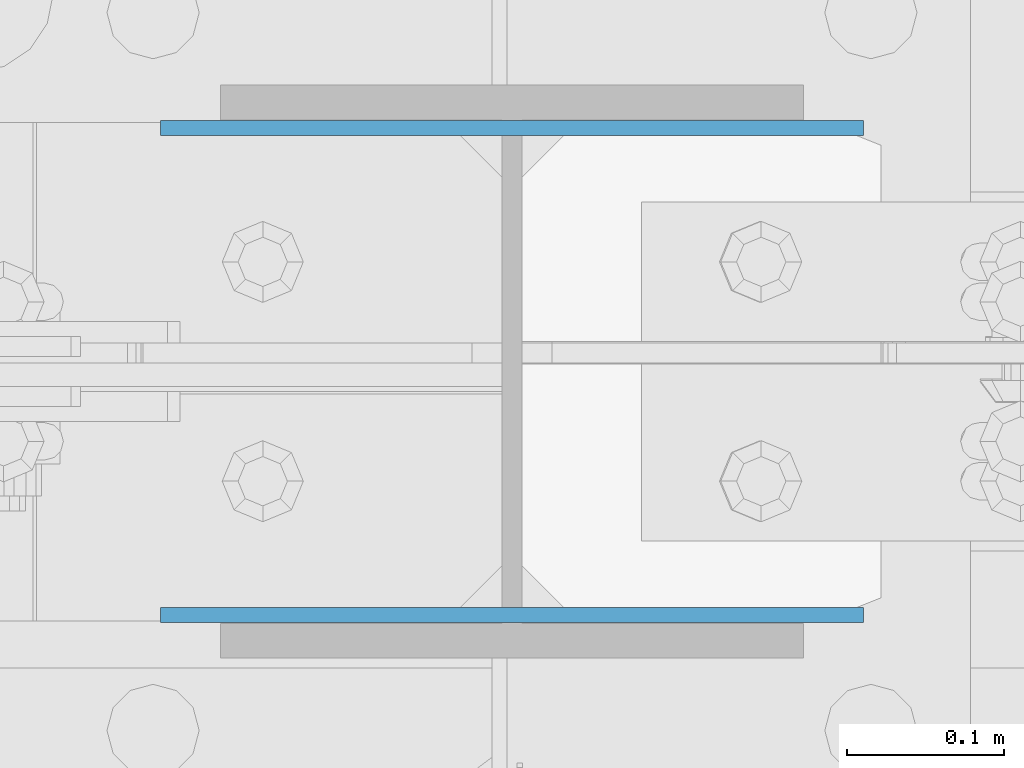
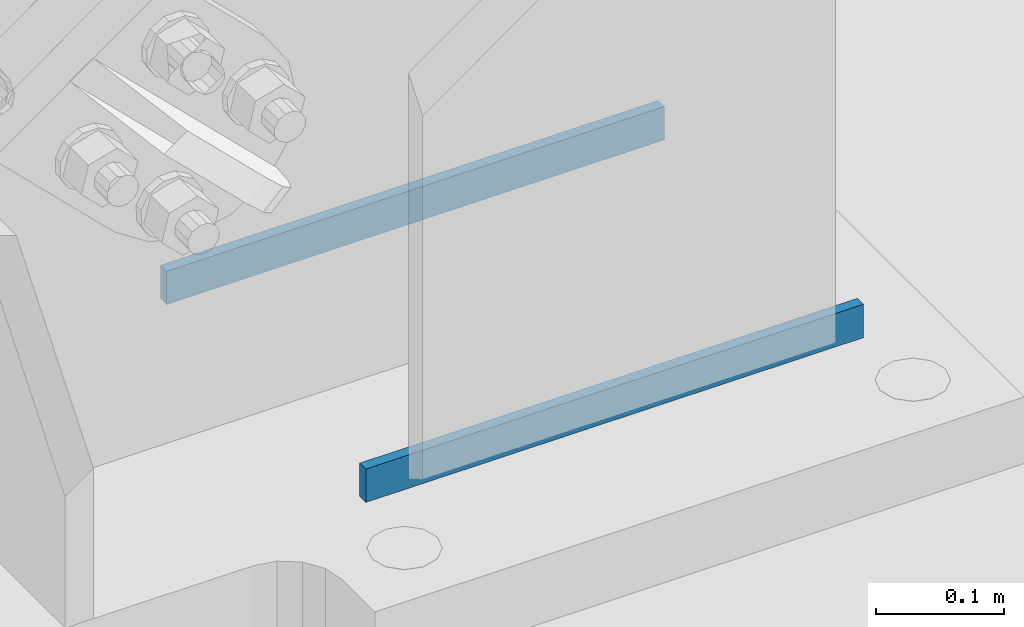
# One storey, part 454 of 1179: 2 columns, 1 element without a shape of its own.
"""IFC2X3 building model written with IfcOpenShell, lengths in millimetres."""

from ifc_helpers import new_model, si_unit, frame, origin_with_axes, place, context, subcontext, project, spatial, faceted_brep, material, type_object, element, aggregate, save


model = new_model("IFC2X3")

# Units and contexts
model_context = context("Model", 3, precision=1e-05, world=origin_with_axes())
body_context = subcontext(model_context, "Body", "Model", "MODEL_VIEW")
ifc_project = project(units=[si_unit("LENGTHUNIT", "METRE", prefix="MILLI"), si_unit("AREAUNIT", "SQUARE_METRE"), si_unit("VOLUMEUNIT", "CUBIC_METRE"), si_unit("MASSUNIT", "GRAM", prefix="KILO"), si_unit("TIMEUNIT", "SECOND"), si_unit("PLANEANGLEUNIT", "RADIAN"), si_unit("SOLIDANGLEUNIT", "STERADIAN"), si_unit("THERMODYNAMICTEMPERATUREUNIT", "DEGREE_CELSIUS"), si_unit("LUMINOUSINTENSITYUNIT", "LUMEN")], contexts=[model_context])

# Site, building, storey
site_placement = place(None, origin_with_axes())
site = spatial("IfcSite", under=ifc_project, at=site_placement, CompositionType="ELEMENT")
building_placement = place(site_placement, origin_with_axes())
building = spatial("IfcBuilding", under=site, at=building_placement, Name="Undefined", CompositionType="ELEMENT")
storey_placement = place(building_placement, origin_with_axes())
storey = spatial("IfcBuildingStorey", under=building, at=storey_placement, Name="Undefined", CompositionType="ELEMENT", Elevation=0.0)

# Assembly, columns
assembly_placement = place(storey_placement, origin_with_axes())
assembly = element("IfcElementAssembly", 1, at=assembly_placement, inside=storey, Name="COLUMN", AssemblyPlace="NOTDEFINED", PredefinedType="RIGID_FRAME")
ifc_material = material(Name="STEEL/A572-GR.50")
column_type = type_object("IfcColumnType", PredefinedType="NOTDEFINED")
column_1_placement = place(assembly_placement, frame((16459.2, 26895.822, -215.9), z_axis=(-1.0, 0.0, 0.0), x_axis=(0.0, 0.0, 1.0)))
column_1 = element("IfcColumn", 2, at=column_1_placement, type_object=column_type, material=ifc_material, Name="PLATE", context=body_context, shape_type="Brep", body=[
    faceted_brep([(0.0, 4.76250000000073, -223.837500000001), (0.0, 4.76250000000073, 223.8375), (31.75, 4.76250000000073, 223.8375), (31.75, 4.76250000000073, -223.837500000001), (0.0, -4.76250000000073, 223.8375), (31.75, -4.76250000000073, 223.8375), (0.0, -4.76250000000073, -223.837500000001), (31.75, -4.76250000000073, -223.837500000001)], [[[0, 1, 2, 3]], [[1, 4, 5, 2]], [[4, 6, 7, 5]], [[6, 0, 3, 7]], [[5, 7, 3, 2]], [[6, 4, 1, 0]]]),
])
column_2_placement = place(assembly_placement, frame((16459.2, 27206.178, -215.9), z_axis=(-1.0, 0.0, 0.0), x_axis=(0.0, 0.0, 1.0)))
column_2 = element("IfcColumn", 3, at=column_2_placement, type_object=column_type, material=ifc_material, Name="PLATE", context=body_context, shape_type="Brep", body=[
    faceted_brep([(0.0, 4.76250000000073, -223.837500000001), (0.0, 4.76250000000073, 223.8375), (31.75, 4.76250000000073, 223.8375), (31.75, 4.76250000000073, -223.837500000001), (0.0, -4.76250000000073, 223.8375), (31.75, -4.76250000000073, 223.8375), (0.0, -4.76250000000073, -223.837500000001), (31.75, -4.76250000000073, -223.837500000001)], [[[0, 1, 2, 3]], [[1, 4, 5, 2]], [[4, 6, 7, 5]], [[6, 0, 3, 7]], [[5, 7, 3, 2]], [[6, 4, 1, 0]]]),
])
aggregate(assembly, [column_1, column_2])

save(model, "model.ifc")
